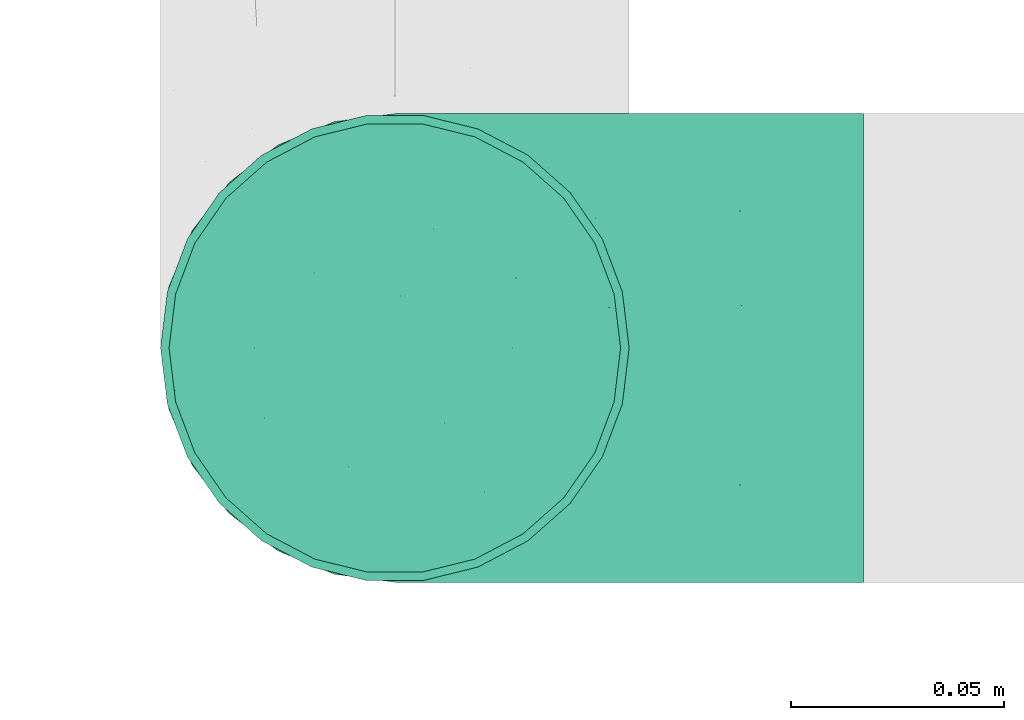
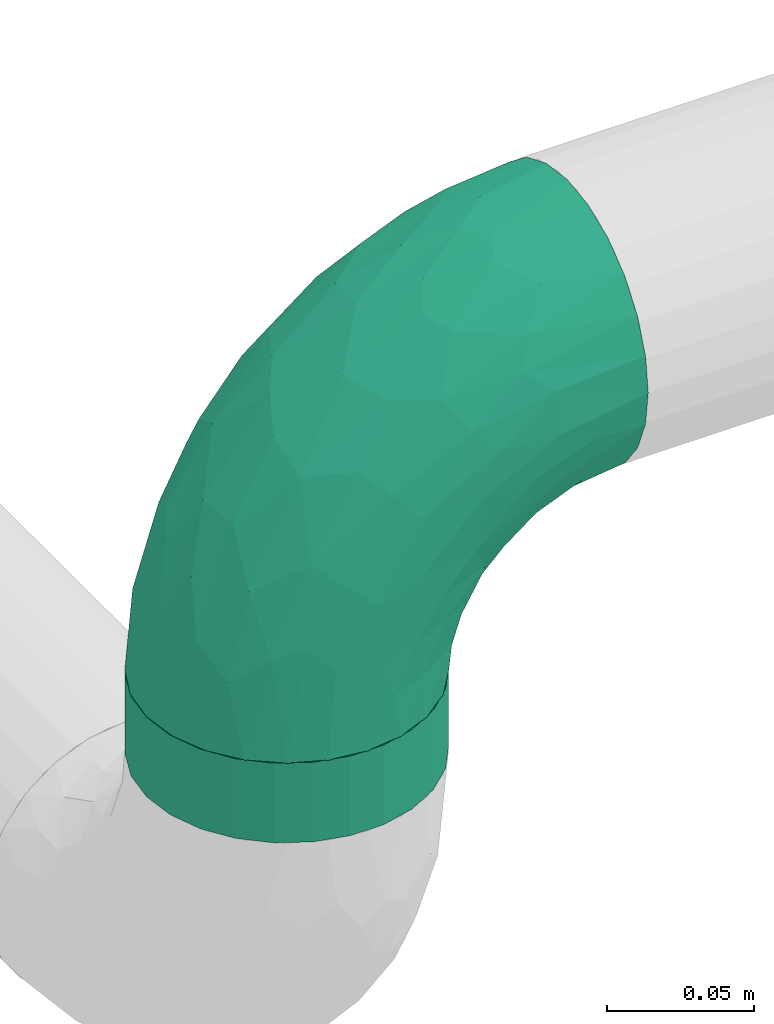
# One storey, part 35 of 91: 1 flow fitting, 1 flow segment.
"""IFC2X3 building model written with IfcOpenShell, lengths in millimetres."""

from ifc_helpers import new_model, entity, si_unit, converted_unit, derived_unit, direction, frame, origin_with_axes, origin_2d_with_axis, place, context, subcontext, project, spatial, hollow_circle, extrude, open_shell, surface_model, source, transform, mapped, material, layer, layer_set, layer_usage, type_object, element, save


model = new_model("IFC2X3")

# Units and contexts
model_context = context("Model", 3, precision=1e-05, world=origin_with_axes(), true_north=direction((0.0, 1.0)))
body_context = subcontext(model_context, "Body", "Model", "MODEL_VIEW")
ifc_project = project(units=[si_unit("AREAUNIT", "SQUARE_METRE"), si_unit("VOLUMEUNIT", "CUBIC_METRE", prefix="DECI"), si_unit("TIMEUNIT", "SECOND"), si_unit("THERMODYNAMICTEMPERATUREUNIT", "DEGREE_CELSIUS"), si_unit("PRESSUREUNIT", "PASCAL"), si_unit("MASSUNIT", "GRAM", prefix="KILO"), si_unit("LENGTHUNIT", "METRE", prefix="MILLI"), si_unit("POWERUNIT", "WATT"), si_unit("ELECTRICCURRENTUNIT", "AMPERE"), si_unit("ELECTRICVOLTAGEUNIT", "VOLT"), derived_unit("VOLUMETRICFLOWRATEUNIT", [(si_unit("VOLUMEUNIT", "CUBIC_METRE", prefix="DECI"), 1), (si_unit("TIMEUNIT", "SECOND"), -1)]), derived_unit("LINEARVELOCITYUNIT", [(si_unit("LENGTHUNIT", "METRE"), 1), (si_unit("TIMEUNIT", "SECOND"), -1)]), derived_unit("MASSDENSITYUNIT", [(si_unit("MASSUNIT", "GRAM", prefix="KILO"), 1), (si_unit("VOLUMEUNIT", "CUBIC_METRE"), -1)]), converted_unit("PLANEANGLEUNIT", "DEGREE", entity("IfcRatioMeasure", 0.01745), si_unit("PLANEANGLEUNIT", "RADIAN"), dimensions=[0, 0, 0, 0, 0, 0, 0])], contexts=[model_context])

# Site, building, storey
site_placement = place(None, origin_with_axes())
site = spatial("IfcSite", under=ifc_project, at=site_placement, CompositionType="ELEMENT")
building_placement = place(site_placement, origin_with_axes())
building = spatial("IfcBuilding", under=site, at=building_placement, Name="mc-building", CompositionType="ELEMENT")
storey_placement = place(building_placement, frame((0.0, 0.0, 8700.0), z_axis=(0.0, 0.0, 1.0), x_axis=(1.0, 0.0, 0.0)))
storey = spatial("IfcBuildingStorey", under=building, at=storey_placement, CompositionType="ELEMENT", Elevation=8700.0)

# Flow segment
ifc_material = material(Name="FZ1")
ifc_layer = layer(ifc_material, 0.0)
ifc_layer_set = layer_set([ifc_layer], Name="FZ1")
ifc_layer_usage = layer_usage(ifc_layer_set, "AXIS1", "POSITIVE", 0.0)
duct_segment_type = type_object("IfcDuctSegmentType", PredefinedType="RIGIDSEGMENT")
shared_shape_1 = source(origin_with_axes(), body_context, "Body", "SweptSolid", [
    extrude(hollow_circle(Radius=55.0, WallThickness=2.0, at=origin_2d_with_axis()), frame((0.0, 0.0, 0.0), z_axis=(1.0, 0.0, 0.0), x_axis=(0.0, 1.0, 0.0)), (0.0, 0.0, 1.0), 33.0),
])
flow_segment_placement = place(storey_placement, frame((5177.14677, 9437.92738, 558.0), z_axis=(0.0, 1.0, 0.0), x_axis=(0.0, 0.0, -1.0)))
element("IfcFlowSegment", 1, at=flow_segment_placement, inside=storey, type_object=duct_segment_type, material=ifc_layer_usage, context=body_context, shape_type="MappedRepresentation", body=[
    mapped(shared_shape_1, transform((0.0, 0.0, 0.0), scale=1.0)),
])

# Flow fitting
duct_fitting_type = type_object("IfcDuctFittingType", Name="BU", PredefinedType="BEND")
shared_shape_2 = source(origin_with_axes(), body_context, "Body", "SurfaceModel", [
    surface_model("IfcShellBasedSurfaceModel", [(-110.0, 0.0, -55.0), (-110.0, -14.23505, -53.12592), (-110.0, 14.23505, -53.12592), (-110.0, 53.12592, 14.23505), (-110.0, 27.5, -47.63139), (-110.0, 38.89087, -38.89087), (-110.0, -55.0, 0.0), (-110.0, -53.12592, 14.23505), (-110.0, -38.89087, -38.89087), (-110.0, -27.5, -47.63139), (-110.0, -53.12592, -14.23505), (-110.0, -47.63139, -27.5), (-110.0, -14.23505, 53.12592), (-110.0, 14.23505, 53.12592), (-110.0, 27.5, 47.63139), (-110.0, -47.63139, 27.5), (-110.0, -38.89087, 38.89087), (-110.0, -27.5, 47.63139), (-110.0, 0.0, 55.0), (-110.0, 55.0, 0.0), (-110.0, 53.12592, -14.23505), (-110.0, 47.63139, -27.5), (-110.0, 47.63139, 27.5), (-110.0, 38.89087, 38.89087), (-14.23505, 110.0, -53.12592), (-55.0, 110.0, 0.0), (0.0, 110.0, -55.0), (-27.5, 110.0, -47.63139), (-38.89087, 110.0, -38.89087), (-47.63139, 110.0, -27.5), (38.89087, 110.0, -38.89087), (53.12592, 110.0, 14.23505), (27.5, 110.0, -47.63139), (14.23505, 110.0, -53.12592), (47.63139, 110.0, -27.5), (53.12592, 110.0, -14.23505), (55.0, 110.0, 0.0), (-53.12592, 110.0, -14.23505), (-53.12592, 110.0, 14.23505), (-47.63139, 110.0, 27.5), (-38.89087, 110.0, 38.89087), (-27.5, 110.0, 47.63139), (0.0, 110.0, 55.0), (-14.23505, 110.0, 53.12592), (38.89087, 110.0, 38.89087), (47.63139, 110.0, 27.5), (27.5, 110.0, 47.63139), (14.23505, 110.0, 53.12592), (-64.21732, 48.68956, 43.63444), (-76.6405, 38.18013, 45.55988), (-60.44912, 32.56953, 51.94617), (-76.00813, 5.38378, 55.0), (-90.15553, 11.94394, 54.09138), (-78.5998, 26.77405, 50.81338), (-70.18771, 18.55163, 54.03432), (-75.55424, 54.2118, 32.41257), (-93.27622, 45.77614, 33.48188), (-96.12334, 22.13664, 50.81337), (-21.00813, 45.34362, 55.0), (-18.36258, 70.48427, 54.04484), (-32.04182, 59.64019, 52.24446), (-63.88653, 74.77858, 17.99134), (-74.66383, 63.08407, 19.92123), (-63.60674, 66.07878, 29.97482), (-99.597, 52.72185, 18.52927), (-93.11138, 56.59448, 10.50359), (-98.21577, 57.34403, 0.0), (-53.42855, 92.60092, 21.04759), (-88.54852, 54.8376, 21.04759), (-11.86161, 90.23965, 54.10313), (-5.38378, 76.00813, 55.0), (-57.34403, 98.21577, 0.0), (-56.64619, 93.12774, 10.22088), (-45.34362, 21.00813, 55.0), (-44.60838, 44.60838, 52.13415), (-92.68484, 35.46673, 43.63443), (-22.25266, 95.40765, 50.81337), (-35.97783, 90.61597, 43.63443), (-43.70931, 69.58671, 44.47149), (-27.23711, 77.39884, 50.81337), (-57.2828, 79.3123, 24.9774), (-58.67786, 84.31125, 16.04456), (-82.93277, 60.36161, 12.91784), (-49.88337, 54.51816, 47.224), (-74.57753, 66.83759, 9.55742), (-45.35812, 94.97281, 33.48188), (-59.18663, 88.95241, 0.0), (-51.517, 78.6292, 33.48188), (-65.14788, 80.03077, 0.0), (-56.45322, 62.06476, 39.63545), (-88.95241, 59.18663, 0.0), (-71.10913, 71.10913, 0.0), (-80.03077, 65.14788, 0.0), (-94.9309, 45.36788, -33.48188), (-93.11358, 56.60141, -10.46614), (-99.64997, 52.79499, -18.30015), (-90.20425, 36.08686, -43.63443), (-79.99933, 46.56772, -37.92748), (-76.00813, 5.38378, -55.0), (-72.75364, 19.68651, -53.60527), (-45.34362, 21.00813, -55.0), (-21.91957, 65.12078, -53.85897), (-5.38378, 76.00813, -55.0), (-21.00813, 45.34362, -55.0), (-35.41876, 92.89265, -43.63443), (-91.10309, 11.02766, -54.21832), (-45.77614, 93.27622, -33.48188), (-90.50474, 23.21022, -50.81337), (-70.92854, 33.31794, -49.51754), (-78.52933, 63.35627, -11.73997), (-24.91508, 84.05606, -50.81337), (-88.78941, 54.74452, -21.04759), (-69.59921, 57.34866, -33.48187), (-73.36422, 62.46673, -22.94182), (-63.49062, 67.59111, -28.46929), (-56.59448, 93.11138, -10.50359), (-54.8376, 88.54852, -21.04759), (-54.10679, 75.85581, -32.31867), (-57.75956, 31.09612, -52.80882), (-52.72185, 99.597, -18.52927), (-12.62913, 89.46304, -53.99097), (-34.46825, 66.46123, -50.04329), (-43.9837, 43.9837, -52.42279), (-65.78527, 72.58348, -17.68796), (-70.34468, 43.65295, -44.21951), (-57.47001, 51.99467, -44.91465), (-60.72547, 82.29174, -12.88567), (-42.34915, 74.24548, -43.63444), (-57.25194, 63.5016, -38.08211), (-80.95344, 53.56991, -29.32027), (-52.32891, 4.55257, -54.0482), (32.52942, 47.13398, -30.48571), (14.88266, 20.92917, -33.7947), (14.95561, 36.05775, -42.26543), (30.24048, 70.09027, -41.7461), (19.3559, 65.35825, -48.00507), (-70.35075, -46.44478, -19.5952), (-47.13398, -32.52942, -30.48571), (-28.49299, -30.5778, -16.4009), (-4.55257, 52.32891, -54.0482), (-22.4954, 22.4954, -53.25347), (-75.47368, -11.22546, -52.60718), (-81.32209, -51.5606, -9.98467), (-80.81763, -41.84862, -32.14655), (-70.09027, -30.24048, -41.7461), (-36.05774, -14.95561, -42.26543), (-9.15831, -10.852, -27.8997), (-65.35825, -19.3559, -48.00507), (11.22546, 75.47368, -52.60718), (3.94376, 43.9333, -50.53315), (-13.39742, 13.39743, -48.13058), (-43.9333, -3.94376, -50.53315), (49.37776, 67.29486, 0.0), (41.8609, 47.82256, -9.92641), (50.20582, 74.51695, -9.9731), (18.93131, 11.7156, -17.56239), (-27.5, -32.89419, 0.0), (-1.23348, -12.25375, -12.18106), (41.84862, 80.81763, -32.14655), (35.70604, 41.31408, -20.38235), (46.44478, 70.35075, -19.5952), (32.89419, 27.5, 0.0), (6.67262, -6.67262, 0.0), (-67.29486, -49.37776, 0.0), (-50.36265, -42.95545, -9.51562), (-5.47251, 5.47251, -39.92906), (-70.35075, -46.44478, 19.5952), (-74.51695, -50.20582, 9.9731), (-41.31407, -35.70604, 20.38235), (-47.13398, -32.52942, 30.48571), (-80.81763, -41.84862, 32.14655), (-4.55257, 52.32891, 54.0482), (11.22546, 75.47368, 52.60718), (-43.9333, -3.94376, 50.53315), (-65.35825, -19.3559, 48.00507), (-36.05774, -14.95561, 42.26543), (-70.09027, -30.24048, 41.7461), (-11.7156, -18.93131, 17.56239), (30.5778, 28.49299, 16.4009), (12.25375, 1.23348, 12.18106), (51.5606, 81.32209, 9.98467), (42.95545, 50.36265, 9.51562), (-75.47368, -11.22546, 52.60718), (-52.32891, 4.55257, 54.0482), (3.94376, 43.9333, 50.53315), (-22.4954, 22.4954, 53.25347), (-13.39742, 13.39743, 48.13058), (10.852, 9.15831, 27.8997), (-20.92916, -14.88266, 33.79469), (-47.82256, -41.8609, 9.92641), (32.52942, 47.13398, 30.48571), (46.44478, 70.35075, 19.5952), (41.84862, 80.81763, 32.14655), (30.24048, 70.09027, 41.7461), (19.3559, 65.35825, 48.00507), (14.95561, 36.05775, 42.26543), (-5.47251, 5.47251, 39.92906)], [open_shell([[[0, 1, 2]], [[2, 3, 4]], [[4, 3, 5]], [[2, 6, 7]], [[8, 6, 9]], [[1, 9, 6]], [[10, 6, 11]], [[8, 11, 6]], [[6, 2, 1]], [[12, 13, 14]], [[15, 2, 7]], [[16, 17, 2]], [[2, 17, 12]], [[12, 18, 13]], [[19, 20, 3]], [[5, 3, 21]], [[20, 21, 3]], [[22, 3, 2]], [[23, 22, 2]], [[12, 14, 2]], [[2, 14, 23]], [[15, 16, 2]], [[24, 25, 26]], [[27, 25, 24]], [[25, 28, 29]], [[28, 25, 27]], [[30, 26, 31]], [[26, 30, 32]], [[32, 33, 26]], [[34, 31, 35]], [[31, 34, 30]], [[35, 31, 36]], [[29, 37, 25]], [[38, 39, 26]], [[39, 40, 26]], [[41, 42, 40]], [[42, 26, 40]], [[42, 41, 43]], [[26, 44, 45]], [[31, 26, 45]], [[26, 46, 44]], [[47, 46, 26]], [[42, 47, 26]], [[25, 38, 26]], [[48, 49, 50]], [[18, 51, 52]], [[53, 54, 50]], [[55, 56, 49]], [[56, 22, 23]], [[13, 57, 14]], [[58, 59, 60]], [[61, 62, 63]], [[3, 64, 65]], [[53, 52, 54]], [[3, 65, 66]], [[67, 39, 38]], [[56, 68, 64]], [[65, 64, 68]], [[69, 59, 70]], [[38, 71, 72]], [[73, 58, 74]], [[75, 49, 56]], [[76, 69, 43]], [[53, 57, 52]], [[77, 78, 79]], [[41, 76, 43]], [[43, 69, 42]], [[55, 68, 56]], [[23, 14, 75]], [[76, 77, 79]], [[80, 67, 81]], [[62, 82, 68]], [[60, 78, 83]], [[62, 84, 82]], [[85, 77, 40]], [[81, 67, 72]], [[86, 72, 71]], [[87, 85, 67]], [[61, 81, 88]], [[77, 41, 40]], [[78, 77, 87]], [[23, 75, 56]], [[83, 89, 48]], [[85, 40, 39]], [[62, 68, 55]], [[89, 87, 63]], [[83, 48, 50]], [[57, 75, 14]], [[49, 75, 53]], [[67, 85, 39]], [[87, 77, 85]], [[63, 62, 55]], [[89, 55, 48]], [[80, 63, 87]], [[66, 65, 90]], [[66, 19, 3]], [[84, 91, 92]], [[92, 90, 82]], [[65, 82, 90]], [[61, 84, 62]], [[92, 82, 84]], [[68, 82, 65]], [[3, 22, 64]], [[56, 64, 22]], [[38, 25, 71]], [[81, 72, 86]], [[38, 72, 67]], [[91, 61, 88]], [[80, 81, 61]], [[63, 80, 61]], [[67, 80, 87]], [[77, 76, 41]], [[79, 59, 69]], [[79, 69, 76]], [[42, 69, 70]], [[60, 59, 79]], [[58, 70, 59]], [[78, 60, 79]], [[58, 60, 74]], [[52, 57, 13]], [[75, 57, 53]], [[18, 52, 13]], [[52, 51, 54]], [[51, 73, 54]], [[50, 73, 74]], [[73, 50, 54]], [[50, 74, 83]], [[60, 83, 74]], [[89, 83, 78]], [[87, 89, 78]], [[55, 89, 63]], [[50, 49, 53]], [[55, 49, 48]], [[81, 86, 88]], [[91, 84, 61]], [[5, 21, 93]], [[90, 94, 66]], [[20, 94, 95]], [[96, 93, 97]], [[98, 99, 100]], [[96, 4, 5]], [[101, 102, 103]], [[28, 27, 104]], [[2, 105, 0]], [[104, 106, 28]], [[99, 105, 107]], [[108, 107, 96]], [[90, 109, 94]], [[107, 2, 4]], [[20, 66, 94]], [[27, 24, 110]], [[109, 111, 94]], [[112, 113, 114]], [[37, 115, 71]], [[116, 106, 117]], [[99, 118, 100]], [[116, 115, 119]], [[37, 119, 115]], [[24, 120, 110]], [[121, 110, 101]], [[119, 106, 116]], [[101, 110, 120]], [[122, 103, 100]], [[117, 123, 116]], [[124, 125, 108]], [[115, 116, 126]], [[106, 29, 28]], [[26, 102, 120]], [[127, 104, 110]], [[97, 124, 96]], [[125, 122, 118]], [[128, 127, 125]], [[96, 5, 93]], [[115, 126, 86]], [[117, 106, 127]], [[111, 113, 129]], [[95, 93, 21]], [[97, 129, 112]], [[110, 104, 27]], [[106, 104, 127]], [[96, 107, 4]], [[99, 107, 108]], [[99, 108, 118]], [[105, 99, 98]], [[112, 114, 128]], [[121, 125, 127]], [[20, 19, 66]], [[109, 90, 92]], [[94, 111, 95]], [[91, 123, 109]], [[129, 113, 112]], [[93, 95, 111]], [[21, 20, 95]], [[71, 115, 86]], [[71, 25, 37]], [[123, 91, 88]], [[126, 116, 123]], [[123, 88, 126]], [[86, 126, 88]], [[37, 29, 119]], [[106, 119, 29]], [[129, 93, 111]], [[124, 112, 125]], [[0, 105, 98]], [[107, 105, 2]], [[125, 118, 108]], [[100, 118, 122]], [[93, 129, 97]], [[113, 111, 109]], [[109, 123, 113]], [[114, 123, 117]], [[123, 114, 113]], [[128, 114, 117]], [[127, 128, 117]], [[112, 128, 125]], [[103, 122, 101]], [[110, 121, 127]], [[101, 122, 121]], [[125, 121, 122]], [[26, 120, 24]], [[101, 120, 102]], [[96, 124, 108]], [[92, 91, 109]], [[112, 124, 97]], [[100, 130, 98]], [[131, 132, 133]], [[32, 134, 135]], [[136, 137, 138]], [[139, 140, 103]], [[98, 141, 0]], [[142, 10, 136]], [[143, 144, 137]], [[6, 10, 142]], [[137, 145, 146]], [[144, 147, 145]], [[143, 136, 11]], [[11, 136, 10]], [[8, 143, 11]], [[148, 149, 139]], [[8, 9, 144]], [[9, 1, 147]], [[130, 141, 98]], [[103, 140, 100]], [[148, 135, 149]], [[150, 151, 140]], [[152, 153, 154]], [[130, 140, 151]], [[148, 26, 33]], [[147, 1, 141]], [[155, 146, 132]], [[156, 138, 157]], [[134, 30, 158]], [[150, 140, 149]], [[158, 30, 34]], [[30, 134, 32]], [[153, 159, 160]], [[131, 160, 159]], [[144, 145, 137]], [[36, 152, 154]], [[146, 138, 137]], [[155, 161, 162]], [[158, 160, 131]], [[133, 149, 135]], [[156, 163, 164]], [[163, 142, 164]], [[139, 103, 102]], [[153, 152, 161]], [[34, 35, 160]], [[162, 157, 155]], [[132, 165, 133]], [[157, 146, 155]], [[140, 130, 100]], [[141, 130, 151]], [[141, 151, 147]], [[141, 1, 0]], [[102, 26, 148]], [[140, 139, 149]], [[102, 148, 139]], [[135, 33, 32]], [[151, 150, 145]], [[9, 147, 144]], [[151, 145, 147]], [[145, 165, 146]], [[135, 148, 33]], [[133, 135, 134]], [[131, 133, 134]], [[133, 165, 150]], [[133, 150, 149]], [[145, 150, 165]], [[132, 131, 159]], [[146, 165, 132]], [[160, 158, 34]], [[134, 158, 131]], [[144, 143, 8]], [[136, 143, 137]], [[155, 153, 161]], [[154, 153, 160]], [[153, 155, 159]], [[132, 159, 155]], [[160, 35, 154]], [[36, 154, 35]], [[164, 136, 138]], [[6, 142, 163]], [[136, 164, 142]], [[156, 164, 138]], [[156, 157, 162]], [[146, 157, 138]], [[15, 7, 166]], [[6, 163, 167]], [[168, 169, 166]], [[166, 169, 170]], [[171, 172, 70]], [[173, 174, 175]], [[17, 176, 174]], [[177, 156, 162]], [[176, 16, 170]], [[170, 16, 15]], [[161, 178, 179]], [[152, 180, 181]], [[182, 173, 183]], [[18, 12, 182]], [[184, 185, 186]], [[183, 185, 73]], [[183, 73, 51]], [[177, 187, 188]], [[189, 168, 166]], [[187, 178, 190]], [[16, 176, 17]], [[161, 152, 181]], [[45, 191, 31]], [[45, 44, 192]], [[192, 191, 45]], [[180, 36, 31]], [[193, 194, 195]], [[46, 47, 194]], [[193, 195, 190]], [[193, 44, 46]], [[172, 42, 70]], [[185, 58, 73]], [[189, 163, 156]], [[163, 189, 167]], [[70, 58, 171]], [[184, 171, 185]], [[169, 188, 175]], [[180, 31, 191]], [[192, 193, 190]], [[191, 190, 178]], [[182, 174, 173]], [[194, 47, 172]], [[190, 195, 187]], [[186, 185, 173]], [[162, 179, 177]], [[188, 196, 175]], [[179, 187, 177]], [[185, 171, 58]], [[172, 171, 184]], [[172, 184, 194]], [[172, 47, 42]], [[51, 18, 182]], [[185, 183, 173]], [[51, 182, 183]], [[174, 12, 17]], [[184, 186, 195]], [[46, 194, 193]], [[184, 195, 194]], [[195, 196, 187]], [[174, 182, 12]], [[175, 174, 176]], [[169, 175, 176]], [[175, 196, 186]], [[175, 186, 173]], [[195, 186, 196]], [[188, 169, 168]], [[187, 196, 188]], [[166, 170, 15]], [[176, 170, 169]], [[193, 192, 44]], [[191, 192, 190]], [[177, 189, 156]], [[167, 189, 166]], [[189, 177, 168]], [[188, 168, 177]], [[166, 7, 167]], [[6, 167, 7]], [[181, 191, 178]], [[36, 180, 152]], [[191, 181, 180]], [[161, 181, 178]], [[161, 179, 162]], [[187, 179, 178]]])]),
])
flow_fitting_placement = place(storey_placement, frame((5177.14677, 9437.92738, 668.0), z_axis=(0.0, 1.0, 0.0), x_axis=(0.0, 0.0, 1.0)))
element("IfcFlowFitting", 2, at=flow_fitting_placement, inside=storey, type_object=duct_fitting_type, Name="BU", context=body_context, shape_type="MappedRepresentation", body=[
    mapped(shared_shape_2, transform((0.0, 0.0, 0.0), scale=1.0)),
])

save(model, "model.ifc")
